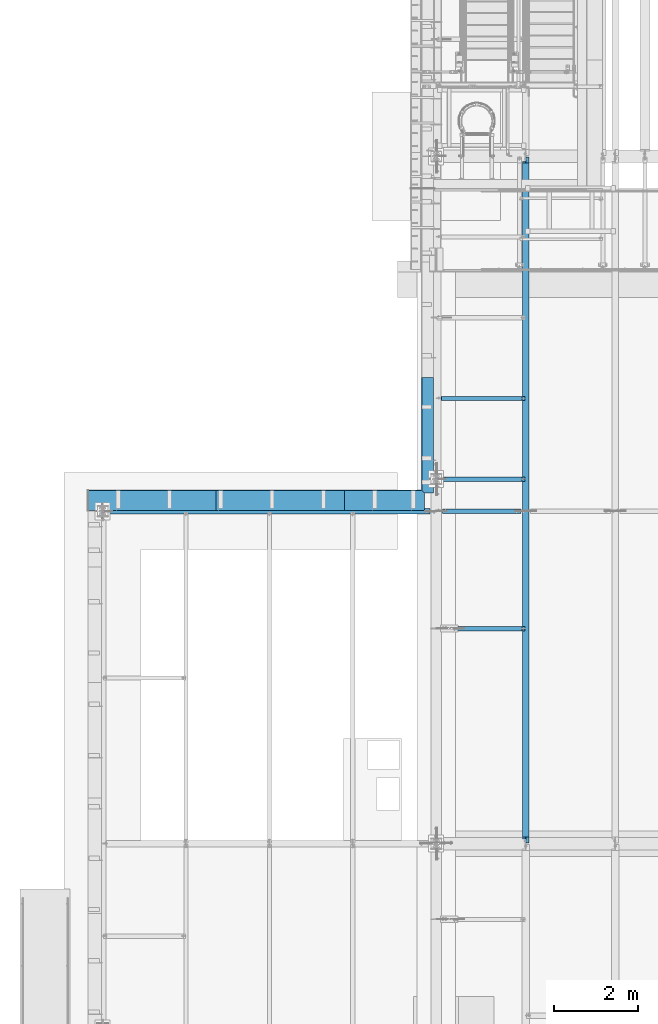
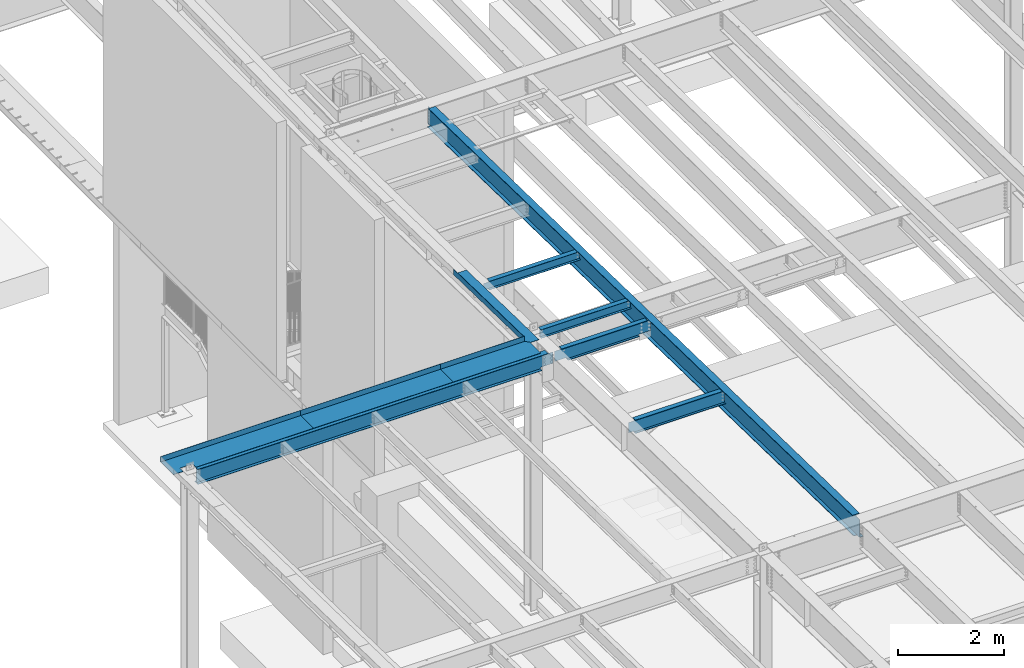
# One storey, part 1071 of 1763: 10 beams, 7 elements without a shape of their own.
"""IFC2X3 building model written with IfcOpenShell, lengths in millimetres."""

from ifc_helpers import new_model, si_unit, frame, origin_with_axes, place, context, subcontext, project, spatial, faceted_brep, material, type_object, element, aggregate, save


model = new_model("IFC2X3")

# Units and contexts
model_context = context("Model", 3, precision=1e-05, world=origin_with_axes())
body_context = subcontext(model_context, "Body", "Model", "MODEL_VIEW")
ifc_project = project(units=[si_unit("LENGTHUNIT", "METRE", prefix="MILLI"), si_unit("AREAUNIT", "SQUARE_METRE"), si_unit("VOLUMEUNIT", "CUBIC_METRE"), si_unit("MASSUNIT", "GRAM", prefix="KILO"), si_unit("TIMEUNIT", "SECOND"), si_unit("PLANEANGLEUNIT", "RADIAN"), si_unit("SOLIDANGLEUNIT", "STERADIAN"), si_unit("THERMODYNAMICTEMPERATUREUNIT", "DEGREE_CELSIUS"), si_unit("LUMINOUSINTENSITYUNIT", "LUMEN")], contexts=[model_context])

# Site, building, storey
site_placement = place(None, origin_with_axes())
site = spatial("IfcSite", under=ifc_project, at=site_placement, CompositionType="ELEMENT")
building_placement = place(site_placement, origin_with_axes())
building = spatial("IfcBuilding", under=site, at=building_placement, Name="Undefined", CompositionType="ELEMENT")
storey_placement = place(building_placement, origin_with_axes())
storey = spatial("IfcBuildingStorey", under=building, at=storey_placement, Name="Undefined", CompositionType="ELEMENT", Elevation=0.0)

# Assembly, beam
assembly_1_placement = place(storey_placement, origin_with_axes())
assembly_1 = element("IfcElementAssembly", 1, at=assembly_1_placement, inside=storey, Name="BEAM", AssemblyPlace="NOTDEFINED", PredefinedType="RIGID_FRAME")
ifc_material_1 = material(Name="STEEL/A992")
beam_type_1 = type_object("IfcBeamType", Name="W8X10", PredefinedType="NOTDEFINED")
beam_1_placement = place(assembly_1_placement, frame((-87375.4372736983, 22352.0, 11350.6526589363), z_axis=(0.0, 0.0, 1.0), x_axis=(1.0, 0.0, 0.0)))
beam_1 = element("IfcBeam", 2, at=beam_1_placement, type_object=beam_type_1, material=ifc_material_1, Name="BEAM", ObjectType="W8X10", context=body_context, shape_type="Brep", body=[
    faceted_brep([(2036.64910714288, -50.7999999999993, 100.012500000001), (2036.64910714288, -50.7999999999993, 95.25), (2036.64910714288, -2.38124999999854, 95.25), (2036.64910714288, -2.38124999999854, 82.2900014933966), (2036.64910714288, 2.38124999999854, 82.2900014933966), (2036.64910714288, 2.38124999999854, 95.25), (2036.64910714288, 50.7999999999993, 95.25), (2036.64910714288, 50.7999999999993, 100.012500000001), (2037.61583706546, -2.38124999999854, 77.4299219753502), (2037.61583706546, 2.38124999999854, 77.4299219753502), (2040.36885096594, -2.38124999999854, 73.3097455071966), (2040.36885096594, 2.38124999999854, 73.3097455071966), (2044.4890274341, -2.38124999999854, 70.556731606719), (2044.4890274341, 2.38124999999854, 70.556731606719), (2049.34910695214, -2.38124999999854, 69.5900016841315), (2049.34910695214, 2.38124999999854, 69.5900016841315), (2050.14286000389, -2.38124999999854, 69.7936271163908), (2050.14286000389, 2.38124999999854, 69.7936271163908), (139.699999999997, -2.38124999999854, -95.25), (139.699999999997, -50.7999999999993, -95.25), (2109.67410714287, -50.7999999999993, -95.25), (2109.67410714287, -2.38124999999854, -95.25), (139.699999999997, -50.7999999999993, -100.012500000001), (2109.67410714287, -50.7999999999993, -100.012500000001), (139.699999999997, 50.7999999999993, -100.012500000001), (2109.67410714287, 50.7999999999993, -100.012500000001), (139.699999999997, 50.7999999999993, -95.25), (2109.67410714287, 50.7999999999993, -95.25), (139.699999999997, -2.38124999999854, 95.25), (139.699999999997, -50.7999999999993, 95.25), (139.699999999997, -50.7999999999993, 100.012500000001), (139.699999999997, 50.7999999999993, 100.012500000001), (139.699999999997, 50.7999999999993, 95.25), (139.699999999997, 2.38124999999854, 95.25), (139.699999999997, 2.38124999999854, -95.25), (2109.67410714287, 2.38124999999854, -95.25), (2109.67410714287, 2.38124999999854, 69.7936271163908), (2109.67410714287, -2.38124999999854, 69.7936271163908)], [[[0, 1, 2, 3, 4, 5, 6, 7]], [[8, 9, 4, 3]], [[10, 11, 9, 8]], [[12, 13, 11, 10]], [[14, 15, 13, 12]], [[16, 17, 15, 14]], [[18, 19, 20, 21]], [[19, 22, 23, 20]], [[22, 24, 25, 23]], [[24, 26, 27, 25]], [[22, 19, 18, 28, 29, 30, 31, 32, 33, 34, 26, 24]], [[26, 34, 35, 27]], [[21, 20, 23, 25, 27, 35, 36, 37]], [[12, 10, 8, 3, 2, 28, 18, 21, 37, 16, 14]], [[29, 28, 2, 1]], [[30, 29, 1, 0]], [[31, 30, 0, 7]], [[32, 31, 7, 6]], [[33, 32, 6, 5]], [[36, 35, 34, 33, 5, 4, 9, 11, 13, 15, 17]], [[37, 36, 17, 16]]]),
])
aggregate(assembly_1, [beam_1])

assembly_2_placement = place(storey_placement, origin_with_axes())
assembly_2 = element("IfcElementAssembly", 3, at=assembly_2_placement, inside=storey, Name="BEAM", AssemblyPlace="NOTDEFINED", PredefinedType="RIGID_FRAME")
beam_2_placement = place(assembly_2_placement, frame((-87375.4372736983, 24269.7, 11310.5204638938), z_axis=(0.0, 0.0, 1.0), x_axis=(1.0, 0.0, 0.0)))
beam_2 = element("IfcBeam", 4, at=beam_2_placement, type_object=beam_type_1, material=ifc_material_1, Name="BEAM", ObjectType="W8X10", context=body_context, shape_type="Brep", body=[
    faceted_brep([(2036.64910714288, -50.7999999999993, 100.012500000001), (2036.64910714288, -50.7999999999993, 95.25), (2036.64910714288, -2.38124999999854, 95.25), (2036.64910714288, -2.38124999999854, 82.2900014933966), (2036.64910714288, 2.38124999999854, 82.2900014933966), (2036.64910714288, 2.38124999999854, 95.25), (2036.64910714288, 50.7999999999993, 95.25), (2036.64910714288, 50.7999999999993, 100.012500000001), (2037.61583706546, -2.38124999999854, 77.4299219753502), (2037.61583706546, 2.38124999999854, 77.4299219753502), (2040.36885096594, -2.38124999999854, 73.3097455071966), (2040.36885096594, 2.38124999999854, 73.3097455071966), (2044.4890274341, -2.38124999999854, 70.556731606719), (2044.4890274341, 2.38124999999854, 70.556731606719), (2049.34910695214, -2.38124999999854, 69.5900016841315), (2049.34910695214, 2.38124999999854, 69.5900016841315), (2050.14286000389, -2.38124999999854, 69.8345316201667), (2050.14286000389, 2.38124999999854, 69.8345316201667), (126.206249999988, -50.7999999999993, 100.012500000001), (126.206249999988, 50.7999999999993, 100.012500000001), (126.206249999988, 50.7999999999993, 95.25), (126.206249999988, 2.38124999999854, 95.25), (126.206249999988, 2.38124999999854, 63.2400015018902), (126.206249999988, -2.38124999999854, 63.2400015018902), (126.206249999988, -2.38124999999854, 95.25), (126.206249999988, -50.7999999999993, 95.25), (125.239520077404, 2.38124999999854, 58.3799219838438), (125.239520077404, -2.38124999999854, 58.3799219838438), (122.486506176923, 2.38124999999854, 54.2597455156902), (122.486506176923, -2.38124999999854, 54.2597455156902), (118.366329708762, 2.38124999999854, 51.5067316152126), (118.366329708762, -2.38124999999854, 51.5067316152126), (113.506250190723, 2.38124999999854, 50.5400016926251), (113.506250190723, -2.38124999999854, 50.5400016926251), (18.2562499999913, 2.38124999999854, 50.5400016926251), (18.2562499999913, -2.38124999999854, 50.5400016926251), (119.856253956619, 50.7999999999993, -95.25), (119.856253956619, 50.7999999999993, -100.012500000001), (119.856292066615, 2.68135427957895, -100.012500000001), (119.856292066746, 2.68114264835822, -95.25), (2109.67410714287, 50.7999999999993, -95.25), (2109.67410714287, 50.7999999999993, -100.012500000001), (2109.67410714287, -50.7999999999993, -95.25), (2109.67410714287, -2.38124999999854, -95.25), (18.2562499999913, -2.38124999999854, -95.25), (18.2562499999913, -2.68143481797597, -95.25), (119.856294836674, -2.68135435090517, -95.25), (119.856332946641, -50.7999999999993, -95.25), (2109.67410714287, -50.7999999999993, -100.012500000001), (119.856332946641, -50.7999999999993, -100.012500000001), (18.2562499999913, -2.68122318676615, -100.012500000001), (18.2562499999913, 2.68127381209342, -100.012500000001), (119.856294836529, -2.68114271968443, -100.012500000001), (18.2562499999913, 2.38124999999854, -95.25), (18.2562499999913, 2.6810621808836, -95.25), (2109.67410714287, 2.38124999999854, -95.25), (2109.67410714287, 2.38124999999854, 69.8345316201667), (2109.67410714287, -2.38124999999854, 69.8345316201667)], [[[0, 1, 2, 3, 4, 5, 6, 7]], [[8, 9, 4, 3]], [[10, 11, 9, 8]], [[12, 13, 11, 10]], [[14, 15, 13, 12]], [[16, 17, 15, 14]], [[18, 19, 20, 21, 22, 23, 24, 25]], [[23, 22, 26, 27]], [[27, 26, 28, 29]], [[29, 28, 30, 31]], [[31, 30, 32, 33]], [[33, 32, 34, 35]], [[36, 37, 38, 39]], [[40, 41, 37, 36]], [[42, 43, 44, 45, 46, 47]], [[48, 42, 47, 49]], [[50, 51, 38, 37, 41, 48, 49, 52]], [[47, 46, 52, 49]], [[45, 50, 52, 46]], [[44, 35, 34, 53, 54, 51, 50, 45]], [[39, 38, 51, 54]], [[53, 55, 40, 36, 39, 54]], [[43, 42, 48, 41, 40, 55, 56, 57]], [[12, 10, 8, 3, 2, 24, 23, 27, 29, 31, 33, 35, 44, 43, 57, 16, 14]], [[25, 24, 2, 1]], [[18, 25, 1, 0]], [[19, 18, 0, 7]], [[20, 19, 7, 6]], [[21, 20, 6, 5]], [[56, 55, 53, 34, 32, 30, 28, 26, 22, 21, 5, 4, 9, 11, 13, 15, 17]], [[57, 56, 17, 16]]]),
])
aggregate(assembly_2, [beam_2])

assembly_3_placement = place(storey_placement, origin_with_axes())
assembly_3 = element("IfcElementAssembly", 5, at=assembly_3_placement, inside=storey, Name="BEAM", AssemblyPlace="NOTDEFINED", PredefinedType="RIGID_FRAME")
beam_type_2 = type_object("IfcBeamType", Name="W14X22", PredefinedType="NOTDEFINED")
beam_3_placement = place(assembly_3_placement, frame((-95300.2372736984, 21590.0, 11303.0), z_axis=(0.0, 0.0, 1.0), x_axis=(1.0, 0.0, 0.0)))
beam_3 = element("IfcBeam", 6, at=beam_3_placement, type_object=beam_type_2, material=ifc_material_1, Name="BEAM", ObjectType="W14X22", context=body_context, shape_type="Brep", body=[
    faceted_brep([(7639.05000000002, -3.17499999999927, -166.6875), (7639.05000000002, -63.5, -166.6875), (7639.05000000002, -63.5, -174.625), (7639.05000000002, 63.5, -174.625), (7639.05000000002, 63.5, -166.6875), (7639.05000000002, 3.17499999999927, -166.6875), (7639.05000000002, 3.17499999999927, -149.224999807899), (7639.05000000002, -3.17499999999927, -149.224999807899), (7640.0167299226, 3.17499999999927, -144.364920289852), (7640.0167299226, -3.17499999999927, -144.364920289852), (7642.76974382308, 3.17499999999927, -140.244743821699), (7642.76974382308, -3.17499999999927, -140.244743821699), (7646.88992029124, 3.17499999999927, -137.491729921221), (7646.88992029124, -3.17499999999927, -137.491729921221), (7651.74999980928, 3.17499999999927, -136.524999998634), (7651.74999980928, -3.17499999999927, -136.524999998634), (7905.75, -3.17499999999927, -136.524999998634), (7905.75, 3.17499999999927, -136.524999998634), (139.699999999997, 3.17499999999927, 166.6875), (139.699999999997, 63.5, 166.6875), (7772.40000000001, 63.5, 166.6875), (7772.40000000001, 3.17499999999927, 166.6875), (139.699999999997, -63.5, -174.625), (139.699999999997, -63.5, -166.6875), (139.699999999997, -3.17499999999927, -166.6875), (139.699999999997, -3.17499999999927, 166.6875), (139.699999999997, -63.5, 166.6875), (139.699999999997, -63.5, 174.625), (139.699999999997, 63.5, 174.625), (139.699999999997, 3.17499999999927, -166.6875), (139.699999999997, 63.5, -166.6875), (139.699999999997, 63.5, -174.625), (7772.40000000001, -3.17499999999927, 166.6875), (7772.40000000001, -63.5, 166.6875), (7772.40000000001, -63.5, 174.625), (7772.40000000001, 63.5, 174.625), (7772.40000000001, -3.17499999999927, 136.524999818135), (7772.40000000001, 3.17499999999927, 136.524999818135), (7773.36672992259, -3.17499999999927, 131.664920300089), (7773.36672992259, 3.17499999999927, 131.664920300089), (7776.11974382307, -3.17499999999927, 127.544743831935), (7776.11974382307, 3.17499999999927, 127.544743831935), (7780.23992029123, -3.17499999999927, 124.791729931458), (7780.23992029123, 3.17499999999927, 124.791729931458), (7785.09999980927, -3.17499999999927, 123.82500000887), (7785.09999980927, 3.17499999999927, 123.82500000887), (7905.75, -3.17499999999927, 123.82500000887), (7905.75, 3.17499999999927, 123.82500000887)], [[[0, 1, 2, 3, 4, 5, 6, 7]], [[7, 6, 8, 9]], [[9, 8, 10, 11]], [[11, 10, 12, 13]], [[13, 12, 14, 15]], [[16, 15, 14, 17]], [[18, 19, 20, 21]], [[22, 23, 24, 25, 26, 27, 28, 19, 18, 29, 30, 31]], [[26, 25, 32, 33]], [[27, 26, 33, 34]], [[28, 27, 34, 35]], [[19, 28, 35, 20]], [[34, 33, 32, 36, 37, 21, 20, 35]], [[38, 39, 37, 36]], [[40, 41, 39, 38]], [[42, 43, 41, 40]], [[44, 45, 43, 42]], [[46, 47, 45, 44]], [[47, 46, 16, 17]], [[12, 10, 8, 6, 5, 29, 18, 21, 37, 39, 41, 43, 45, 47, 17, 14]], [[30, 29, 5, 4]], [[31, 30, 4, 3]], [[22, 31, 3, 2]], [[23, 22, 2, 1]], [[24, 23, 1, 0]], [[46, 44, 42, 40, 38, 36, 32, 25, 24, 0, 7, 9, 11, 13, 15, 16]]]),
])

assembly_4_placement = place(storey_placement, origin_with_axes())
assembly_4 = element("IfcElementAssembly", 7, at=assembly_4_placement, inside=storey, Name="BEAM", AssemblyPlace="NOTDEFINED", PredefinedType="RIGID_FRAME")
ifc_material_2 = material(Name="STEEL/A36")
beam_type_3 = type_object("IfcBeamType", PredefinedType="NOTDEFINED")
beam_4_placement = place(assembly_4_placement, frame((-87438.9372736983, 23396.4437971548, 11431.9586764796), z_axis=(0.0, -0.999781691287208, 0.0208942520059919), x_axis=(-1.0, 0.0, 0.0)))
beam_4 = element("IfcBeam", 8, at=beam_4_placement, type_object=beam_type_3, material=ifc_material_2, Name="BENT_PLATE", context=body_context, shape_type="Brep", body=[
    faceted_brep([(285.781826031234, -123.824999976632, 1297.80508087004), (285.74999999463, 3.1750000103184, 1295.15093144183), (209.558023682039, 3.17500000767723, 1371.60000000009), (209.690340115238, -3.1749999923195, 1371.60000000008), (279.399999994639, -3.17499998990024, 1301.68432532831), (279.399999993111, -123.824999976636, 1304.20576728683), (2.91038304567337e-11, -3.17499999963729, -1371.60000000396), (-2.91038304567337e-11, -3.17500000036489, 1371.60000000395), (-2.91038304567337e-11, 3.17499999963184, 1371.60000000395), (2.91038304567337e-11, 3.17500000035943, -1371.60000000396), (279.400000000271, -3.1750000001648, -1371.59999999897), (285.750000000276, 3.17499999982283, -1371.59999999897), (285.750000000218, -123.824997298212, -1371.59999999898), (279.400000000212, -123.824997298212, -1371.59999999898)], [[[0, 1, 2, 3, 4, 5]], [[6, 7, 8, 9]], [[10, 6, 9, 11, 12, 13]], [[13, 12, 0, 5]], [[10, 13, 5, 4]], [[7, 6, 10, 4, 3]], [[8, 7, 3, 2]], [[11, 9, 8, 2, 1]], [[12, 11, 1, 0]]]),
])
aggregate(assembly_4, [beam_4])

# Beam
beam_type_4 = type_object("IfcBeamType", PredefinedType="NOTDEFINED")
beam_5_placement = place(assembly_3_placement, frame((-94125.4872736984, 21602.7, 11480.8), z_axis=(-1.0, 0.0, 0.0), x_axis=(0.0, 1.0, 0.0)))
beam_5 = element("IfcBeam", 9, at=beam_5_placement, type_object=beam_type_4, material=ifc_material_2, Name="BENT_PLATE", context=body_context, shape_type="Brep", body=[
    faceted_brep([(126.999999999975, -3.17499999999927, 1035.05), (126.999999999975, 3.17499999999927, 1035.05), (0.0, 3.17499999999927, 1035.05), (0.0, -3.17499999999927, 1035.05), (126.999999999975, -3.17499999999927, 1314.45002441407), (126.999999999975, 3.17499999999927, 1314.45002441407), (0.0, -3.17499999999927, 1314.45002441407), (0.0, 3.17499999999927, 1314.45002441407), (482.600012207033, -3.17499999999927, 1524.0), (482.600012207033, -3.17499999999927, -1524.0), (482.600012207033, -123.825000000001, -1524.0), (482.600012207033, -123.825000000001, 1524.0), (488.950012207031, 3.17499999999927, 1524.0), (0.0, 3.17499999999927, 1524.0), (0.0, -3.17499999999927, 1524.0), (488.950012207031, -123.825000000001, 1524.0), (488.950012207031, 3.17499999999927, -1524.0), (488.950012207031, -123.825000000001, -1524.0), (0.0, -3.17499999999927, -1523.99999999999), (0.0, 3.17499999999927, -1523.99999999999)], [[[0, 1, 2, 3]], [[4, 5, 1, 0]], [[6, 7, 5, 4]], [[8, 9, 10, 11]], [[12, 13, 14, 8, 11, 15]], [[16, 12, 15, 17]], [[11, 10, 17, 15]], [[9, 18, 19, 16, 17, 10]], [[19, 18, 3, 2]], [[13, 12, 16, 19, 2, 1, 5, 7]], [[14, 13, 7, 6]], [[3, 18, 9, 8, 14, 6, 4, 0]]]),
])

beam_6_placement = place(assembly_3_placement, frame((-88600.9872736984, 21602.7, 11480.8), z_axis=(-1.0, 0.0, 0.0), x_axis=(0.0, 1.0, 0.0)))
beam_6 = element("IfcBeam", 10, at=beam_6_placement, type_object=beam_type_4, material=ifc_material_2, Name="BENT_PLATE", context=body_context, shape_type="Brep", body=[
    faceted_brep([(0.0, -3.17499999999927, -952.5), (0.0, -3.17499999999927, 952.5), (0.0, 3.17499999999927, 952.5), (0.0, 3.17499999999927, -952.5), (488.950012207031, 3.17499999999927, 952.5), (482.600012207033, -3.17499999999927, 952.5), (482.600012207033, -123.825000000001, 952.5), (488.950012207031, -123.825000000001, 952.5), (488.950012207031, -123.825000000001, -876.30000488575), (488.950012207031, 3.17499999999927, -876.30000488575), (412.549549837691, 3.17499999999927, -952.5), (412.549549837691, -3.17499999999927, -952.5), (482.600012207033, -3.17499999999927, -882.63334311395), (482.600012207033, -123.825000000001, -882.63334311395)], [[[0, 1, 2, 3]], [[4, 2, 1, 5, 6, 7]], [[4, 7, 8, 9]], [[3, 2, 4, 9, 10]], [[0, 3, 10, 11]], [[5, 1, 0, 11, 12]], [[6, 5, 12, 13]], [[7, 6, 13, 8]], [[12, 11, 10, 9, 8, 13]]]),
])

beam_7_placement = place(assembly_3_placement, frame((-91077.4872736984, 21602.7, 11480.8), z_axis=(-1.0, 0.0, 0.0), x_axis=(0.0, 1.0, 0.0)))
beam_7 = element("IfcBeam", 11, at=beam_7_placement, type_object=beam_type_4, material=ifc_material_2, Name="BENT_PLATE", context=body_context, shape_type="Brep", body=[
    faceted_brep([(0.0, -3.17499999999927, -1523.99999999999), (0.0, -3.17499999999927, 1524.0), (0.0, 3.17499999999927, 1524.0), (0.0, 3.17499999999927, -1523.99999999999), (488.950012207031, 3.17499999999927, 1524.0), (488.950012207031, 3.17499999999927, -1524.0), (482.600012207033, -3.17499999999927, -1524.0), (482.600012207033, -3.17499999999927, 1524.0), (488.950012207031, -123.825000000001, 1524.0), (488.950012207031, -123.825000000001, -1524.0), (482.600012207033, -123.825000000001, 1524.0), (482.600012207033, -123.825000000001, -1524.0)], [[[0, 1, 2, 3]], [[3, 2, 4, 5]], [[1, 0, 6, 7]], [[5, 4, 8, 9]], [[4, 2, 1, 7, 10, 8]], [[7, 6, 11, 10]], [[6, 0, 3, 5, 9, 11]], [[10, 11, 9, 8]]]),
])

aggregate(assembly_3, [beam_5, beam_6, beam_7, beam_3])

# Assembly, beam
assembly_5_placement = place(storey_placement, origin_with_axes())
assembly_5 = element("IfcElementAssembly", 12, at=assembly_5_placement, inside=storey, Name="BEAM", AssemblyPlace="NOTDEFINED", PredefinedType="RIGID_FRAME")
beam_type_5 = type_object("IfcBeamType", Name="W18X40", PredefinedType="NOTDEFINED")
beam_8_placement = place(assembly_5_placement, frame((-85249.0944165555, 13685.8551306872, 11404.7768219843), z_axis=(0.0, 0.0209013539966291, 0.999781542838788), x_axis=(0.0, 0.999781542776098, -0.0209013569953182)))
beam_8 = element("IfcBeam", 13, at=beam_8_placement, type_object=beam_type_5, material=ifc_material_1, Name="BEAM", ObjectType="W18X40", context=body_context, shape_type="Brep", body=[
    faceted_brep([(126.194002738479, 4.26866853985121, -214.312499999893), (126.194002738466, 4.2688283926982, -227.01249999989), (29.339897632873, 4.26882972748717, -227.01250000019), (29.0743924101943, 4.26863241521642, -214.31250000018), (126.193992739341, 76.1999999999971, -214.312499999894), (126.193992739347, 76.1999999999971, -227.01249999989), (164.293992016979, -3.96875, 195.002501487832), (164.293992016979, 3.96875, 195.002501487832), (163.327262094397, 3.96875, 190.142421969791), (163.327262094397, -3.96875, 190.142421969791), (160.574248193921, 3.96875, 186.022245501637), (160.574248193921, -3.96875, 186.022245501637), (156.454071725771, 3.96875, 183.269231601158), (156.454071725771, -3.96875, 183.269231601158), (151.593992207727, 3.96875, 182.302501678567), (151.593992207727, -3.96875, 182.302501678567), (20.7827897637508, 3.96875, 182.30250167849), (20.7827897637508, -3.96875, 182.30250167849), (29.0743924101943, -3.96875, -214.31250000018), (16325.1468877506, -3.96875, -214.312499990354), (16317.1207899894, -3.96875, 169.60249800784), (16187.3164864569, -3.96875, 169.602498007764), (16182.4564069388, -3.96875, 170.569227930349), (16178.3362304707, -3.96875, 173.322241830821), (16175.5832165702, -3.96875, 177.442418298971), (16174.6164866476, -3.96875, 182.302497817014), (16174.6164868948, -3.96875, 214.312500009495), (164.29399201697, -3.96875, 214.312500000067), (29.0743924101943, -76.1999999999971, -214.31250000018), (16325.1468877506, -76.1999999999971, -214.312499990354), (29.339897632873, -76.1999999999971, -227.01250000019), (16325.412392986, -76.1999999999971, -227.012499990351), (16225.1450550741, 76.1999999999971, -215.844156205017), (16225.1450550741, 4.71875000001455, -215.844156205017), (16225.4164836211, 4.71875000001455, -215.838481740431), (16225.4164771875, 76.1999999999971, -215.838481874931), (16225.1130343856, 4.71875000001455, -214.312499990412), (16225.1130343856, 76.1999999999971, -214.312499990412), (16225.4164836211, 4.71875000001455, -214.312499990414), (16225.4164838328, 4.26882845565706, -214.312499990412), (16225.4164838328, 4.26866860519658, -227.012499990411), (16225.4164773588, 76.1999999999971, -227.012499990409), (16325.412392986, 4.2686776052069, -227.012499990351), (16325.1468877506, 4.26883743175858, -214.312499990354), (16325.1468877506, 3.96875, -214.312499990354), (16317.1207899894, 3.96875, 169.60249800784), (16187.3164864569, 3.96875, 169.602498007764), (16182.4564069388, 3.96875, 170.569227930349), (16178.3362304707, 3.96875, 173.322241830821), (16175.5832165702, 3.96875, 177.442418298971), (16174.6164866476, 3.96875, 182.302497817014), (16174.6164868948, -76.1999999999971, 227.01250000949), (16174.6164868948, -76.1999999999971, 214.312500009495), (16174.6164868948, 3.96875, 214.312500009495), (16174.6164868948, 76.1999999999971, 214.312500009495), (16174.6164868948, 76.1999999999971, 227.01250000949), (164.29399201697, 3.96875, 214.312500000067), (164.29399201697, 76.1999999999971, 214.312500000067), (164.293992016963, 76.1999999999971, 227.012500000064), (164.293992016963, -76.1999999999971, 227.012500000064), (164.29399201697, -76.1999999999971, 214.312500000067), (29.0743924101943, 3.96875, -214.31250000018)], [[[0, 1, 2, 3]], [[4, 5, 1, 0]], [[6, 7, 8, 9]], [[9, 8, 10, 11]], [[11, 10, 12, 13]], [[13, 12, 14, 15]], [[15, 14, 16, 17]], [[9, 11, 13, 15, 17, 18, 19, 20, 21, 22, 23, 24, 25, 26, 27, 6]], [[18, 28, 29, 19]], [[28, 30, 31, 29]], [[32, 33, 34, 35]], [[36, 33, 32, 37]], [[33, 36, 38, 34]], [[39, 40, 41, 35, 34, 38]], [[42, 40, 39, 43]], [[44, 45, 20, 19, 29, 31, 42, 43]], [[20, 45, 46, 21]], [[21, 46, 47, 22]], [[22, 47, 48, 23]], [[23, 48, 49, 24]], [[24, 49, 50, 25]], [[51, 52, 26, 25, 50, 53, 54, 55]], [[54, 53, 56, 57]], [[55, 54, 57, 58]], [[51, 55, 58, 59]], [[52, 51, 59, 60]], [[26, 52, 60, 27]], [[59, 58, 57, 56, 7, 6, 27, 60]], [[53, 50, 49, 48, 47, 46, 45, 44, 61, 16, 14, 12, 10, 8, 7, 56]], [[30, 28, 18, 17, 16, 61, 3, 2]], [[41, 40, 42, 31, 30, 2, 1, 5]], [[37, 32, 35, 41, 5, 4]], [[61, 44, 43, 39, 38, 36, 37, 4, 0, 3]]]),
])
aggregate(assembly_5, [beam_8])

assembly_6_placement = place(storey_placement, origin_with_axes())
assembly_6 = element("IfcElementAssembly", 14, at=assembly_6_placement, inside=storey, Name="BEAM", AssemblyPlace="NOTDEFINED", PredefinedType="RIGID_FRAME")
beam_type_6 = type_object("IfcBeamType", Name="W12X22", PredefinedType="NOTDEFINED")
beam_9_placement = place(assembly_6_placement, frame((-87375.4372736983, 18796.0, 11369.4316248404), z_axis=(0.0, 0.0, 1.0), x_axis=(1.0, 0.0, 0.0)))
beam_9 = element("IfcBeam", 15, at=beam_9_placement, type_object=beam_type_6, material=ifc_material_1, Name="BEAM", ObjectType="W12X22", context=body_context, shape_type="Brep", body=[
    faceted_brep([(20.6374999999971, -3.17499999999927, -123.824999999781), (20.6374999999971, 3.17499999999927, -123.824999999781), (128.587500190726, 3.17500001968983, -123.824999999781), (128.587500190726, -3.17499999999927, -123.824999999781), (133.447579708765, 3.17500001977351, -124.791729922368), (133.447579708765, -3.17499999999927, -124.791729922368), (137.567756176926, 3.17500002000997, -127.544743822846), (137.567756176926, -3.17499999999927, -127.544743822846), (140.320770077407, 3.17500002036286, -131.664920290999), (140.320770077407, -3.17499999999927, -131.664920290999), (141.287499999991, -3.17499999999927, -136.524999809046), (141.287499999991, 3.17500002077941, -136.524999809046), (141.287500000006, 3.17500004903195, -144.4625), (141.287500000006, 50.7999999999993, -144.4625), (141.287500000006, 50.7999999999993, -155.575000000001), (141.287499999991, -50.7999999999993, -155.575000000001), (141.287499999991, -50.7999999999993, -144.4625), (141.287499999991, -3.17499999999927, -144.4625), (2033.47410714286, 50.7999999999993, 144.4625), (2033.47410714286, 3.17499999999927, 144.4625), (141.287499999991, 3.17499999999927, 144.4625), (141.287499999991, 50.7999999999993, 144.4625), (128.587500190726, -3.17499999999927, 111.12500000022), (128.587500190726, 3.17499999968095, 111.12500000022), (20.6374999999971, 3.17499999999927, 111.12500000022), (20.6374999999971, -3.17499999999927, 111.12500000022), (133.447579708765, -3.17499999999927, 112.091729922808), (133.447579708765, 3.17499999959728, 112.091729922808), (137.567756176926, -3.17499999999927, 114.844743823285), (137.567756176926, 3.17499999936263, 114.844743823285), (140.320770077407, -3.17499999999927, 118.964920291439), (140.320770077407, 3.17499999901156, 118.964920291439), (141.287499999991, -3.17499999999927, 123.824999809485), (141.287499999991, 3.17499999859865, 123.824999809485), (2033.47410714286, -50.7999999999993, 155.575000000001), (2033.47410714286, 50.7999999999993, 155.575000000001), (141.287499999991, 50.7999999999993, 155.575000000001), (141.287499999991, -50.7999999999993, 155.575000000001), (2033.47410714286, -50.7999999999993, 144.4625), (141.287499999991, -50.7999999999993, 144.4625), (2033.47410714286, -3.17499999999927, 144.4625), (141.287499999991, -3.17499999999927, 144.4625), (2033.47410714286, -3.17499999999927, 136.265001487105), (2033.47410714286, 3.17499999999927, 136.265001487105), (2034.44083706544, -3.17499999999927, 131.404921969059), (2034.44083706544, 3.17499999999927, 131.404921969059), (2037.19385096592, -3.17499999999927, 127.284745500905), (2037.19385096592, 3.17499999999927, 127.284745500905), (2041.31402743408, -3.17499999999927, 124.531731600428), (2041.31402743408, 3.17499999999927, 124.531731600428), (2046.17410695212, -3.17499999999927, 123.56500167784), (2046.17410695212, 3.17499999999927, 123.56500167784), (2109.67410714286, -3.17499999999927, 123.56500167784), (2109.67410714286, 3.17499999999927, 123.56500167784), (2109.67410714286, -3.17499999999927, -144.4625), (2109.67410714286, -50.7999999999993, -144.4625), (2109.67410714286, -50.7999999999993, -155.575000000001), (2109.67410714286, 50.7999999999993, -155.575000000001), (2109.67410714286, 50.7999999999993, -144.4625), (2109.67410714286, 3.17499999999927, -144.4625)], [[[0, 1, 2, 3]], [[3, 2, 4, 5]], [[5, 4, 6, 7]], [[7, 6, 8, 9]], [[10, 11, 12, 13, 14, 15, 16, 17]], [[9, 8, 11, 10]], [[18, 19, 20, 21]], [[22, 23, 24, 25]], [[26, 27, 23, 22]], [[28, 29, 27, 26]], [[30, 31, 29, 28]], [[32, 33, 31, 30]], [[34, 35, 36, 37]], [[38, 34, 37, 39]], [[40, 38, 39, 41]], [[37, 36, 21, 20, 33, 32, 41, 39]], [[35, 18, 21, 36]], [[34, 38, 40, 42, 43, 19, 18, 35]], [[44, 45, 43, 42]], [[46, 47, 45, 44]], [[48, 49, 47, 46]], [[50, 51, 49, 48]], [[52, 53, 51, 50]], [[54, 55, 56, 57, 58, 59, 53, 52]], [[55, 54, 17, 16]], [[56, 55, 16, 15]], [[57, 56, 15, 14]], [[58, 57, 14, 13]], [[59, 58, 13, 12]], [[6, 4, 2, 1, 24, 23, 27, 29, 31, 33, 20, 19, 43, 45, 47, 49, 51, 53, 59, 12, 11, 8]], [[25, 24, 1, 0]], [[54, 52, 50, 48, 46, 44, 42, 40, 41, 32, 30, 28, 26, 22, 25, 0, 3, 5, 7, 9, 10, 17]]]),
])
aggregate(assembly_6, [beam_9])

assembly_7_placement = place(storey_placement, origin_with_axes())
assembly_7 = element("IfcElementAssembly", 16, at=assembly_7_placement, inside=storey, Name="BEAM", AssemblyPlace="NOTDEFINED", PredefinedType="RIGID_FRAME")
beam_10_placement = place(assembly_7_placement, frame((-87375.4372736983, 21589.9999999839, 11311.0204686664), z_axis=(0.0, 0.0, 1.0), x_axis=(1.0, 0.0, 0.0)))
beam_10 = element("IfcBeam", 17, at=beam_10_placement, type_object=beam_type_6, material=ifc_material_1, Name="BEAM", ObjectType="W12X22", context=body_context, shape_type="Brep", body=[
    faceted_brep([(19.0500000000175, -3.17499999999927, -117.474999991142), (19.0500000000175, 3.17499999999927, -117.474999991142), (273.050000190749, 3.17500002180896, -117.474999991142), (273.050000190749, -3.17499999999927, -117.474999991142), (277.910079708789, 3.17500002195447, -118.441729913729), (277.910079708789, -3.17499999999927, -118.441729913729), (282.030256176949, 3.17500002235465, -121.194743814207), (282.030256176949, -3.17499999999927, -121.194743814207), (284.783270077431, 3.17500002295856, -125.314920282361), (284.783270077431, -3.17499999999927, -125.314920282361), (285.750000000015, -3.17499999999927, -130.174999800407), (285.750000000015, 3.17500002366432, -130.174999800407), (285.750000000015, 3.1750000952652, -144.4625), (285.750000000015, 50.7999999999993, -144.4625), (285.750000000015, 50.7999999999993, -155.575000000001), (285.750000000015, -50.7999999999993, -155.575000000001), (285.750000000015, -50.7999999999993, -144.4625), (285.750000000015, -3.17499999999927, -144.4625), (2014.42410714286, 50.7999999999993, 144.4625), (2014.42410714286, 3.17499999999927, 144.4625), (152.400000000023, 3.17499999999927, 144.4625), (152.400000000023, 50.7999999999993, 144.4625), (139.700000190758, -3.17499999999927, 117.475000008859), (139.700000190758, 3.17499998832136, 117.475000008859), (19.0500000000029, 3.17499999999927, 117.475000001421), (19.0500000000029, -3.17499999999927, 117.475000001421), (144.560079708797, -3.17499999999927, 118.441729931446), (144.560079708797, 3.17499998818312, 118.441729931446), (148.680256176958, -3.17499999999927, 121.194743831924), (148.680256176958, 3.17499998779022, 121.194743831924), (151.433270077439, -3.17499999999927, 125.314920300078), (151.433270077439, 3.17499998719722, 125.314920300078), (152.400000000023, -3.17499999999927, 130.174999818124), (152.400000000023, 3.17499998650237, 130.174999818124), (2014.42410714286, -50.7999999999993, 155.575000000001), (2014.42410714286, 50.7999999999993, 155.575000000001), (152.400000000023, 50.7999999999993, 155.575000000001), (152.400000000023, -50.7999999999993, 155.575000000001), (2014.42410714286, -50.7999999999993, 144.4625), (152.400000000023, -50.7999999999993, 144.4625), (2014.42410714286, -3.17499999999927, 144.4625), (152.400000000023, -3.17499999999927, 144.4625), (2014.42410714286, -3.17499999999927, 142.874999813634), (2014.42410714286, 3.17499999175197, 142.874999813634), (2015.39083706544, -3.17499999999927, 138.014920295587), (2015.39083706544, 3.17499999248685, 138.014920295587), (2018.14385096592, -3.17499999999927, 133.894743827434), (2018.14385096592, 3.17499999310894, 133.894743827434), (2022.26402743408, -3.17499999999927, 131.141729926956), (2022.26402743408, 3.17499999352367, 131.141729926956), (2027.12410695212, -3.17499999999927, 130.175000004368), (2027.12410695212, 3.17499999366555, 130.175000004368), (2109.67410714286, -3.17499999999927, 130.175000004368), (2109.67410714286, 3.17499999999927, 130.175000004368), (2109.67410714286, -3.17499999999927, -130.174999995632), (2109.67410714286, 3.17499999999927, -130.174999995632), (1855.67410695212, -3.17499999999927, -130.174999995632), (1855.67410695212, 3.17500003318855, -130.174999995632), (1850.81402743408, -3.17499999999927, -131.141729918219), (1850.81402743408, 3.17500003334135, -131.141729918219), (1846.69385096592, -3.17499999999927, -133.894743818697), (1846.69385096592, 3.17500003376699, -133.894743818697), (1843.94083706544, -3.17499999999927, -138.014920286851), (1843.94083706544, 3.17500003439636, -138.014920286851), (1842.97410714286, -3.17499999999927, -142.874999804897), (1842.97410714286, 3.17500003513851, -142.874999804897), (1842.97410714286, -3.17499999999927, -144.4625), (1842.97410714286, -50.7999999999993, -144.4625), (1842.97410714286, -50.7999999999993, -155.575000000001), (1842.97410714286, 50.7999999999993, -155.575000000001), (1842.97410714286, 50.7999999999993, -144.4625), (1842.97410714286, 3.1750000136708, -144.4625)], [[[0, 1, 2, 3]], [[3, 2, 4, 5]], [[5, 4, 6, 7]], [[7, 6, 8, 9]], [[10, 11, 12, 13, 14, 15, 16, 17]], [[9, 8, 11, 10]], [[18, 19, 20, 21]], [[22, 23, 24, 25]], [[26, 27, 23, 22]], [[28, 29, 27, 26]], [[30, 31, 29, 28]], [[32, 33, 31, 30]], [[34, 35, 36, 37]], [[38, 34, 37, 39]], [[40, 38, 39, 41]], [[37, 36, 21, 20, 33, 32, 41, 39]], [[35, 18, 21, 36]], [[34, 38, 40, 42, 43, 19, 18, 35]], [[44, 45, 43, 42]], [[46, 47, 45, 44]], [[48, 49, 47, 46]], [[50, 51, 49, 48]], [[52, 53, 51, 50]], [[53, 52, 54, 55]], [[54, 56, 57, 55]], [[58, 59, 57, 56]], [[60, 61, 59, 58]], [[62, 63, 61, 60]], [[64, 65, 63, 62]], [[66, 67, 68, 69, 70, 71, 65, 64]], [[67, 66, 17, 16]], [[68, 67, 16, 15]], [[69, 68, 15, 14]], [[70, 69, 14, 13]], [[71, 70, 13, 12]], [[6, 4, 2, 1, 24, 23, 27, 29, 31, 33, 20, 19, 43, 45, 47, 49, 51, 53, 55, 57, 59, 61, 63, 65, 71, 12, 11, 8]], [[25, 24, 1, 0]], [[66, 64, 62, 60, 58, 56, 54, 52, 50, 48, 46, 44, 42, 40, 41, 32, 30, 28, 26, 22, 25, 0, 3, 5, 7, 9, 10, 17]]]),
])
aggregate(assembly_7, [beam_10])

save(model, "model.ifc")
